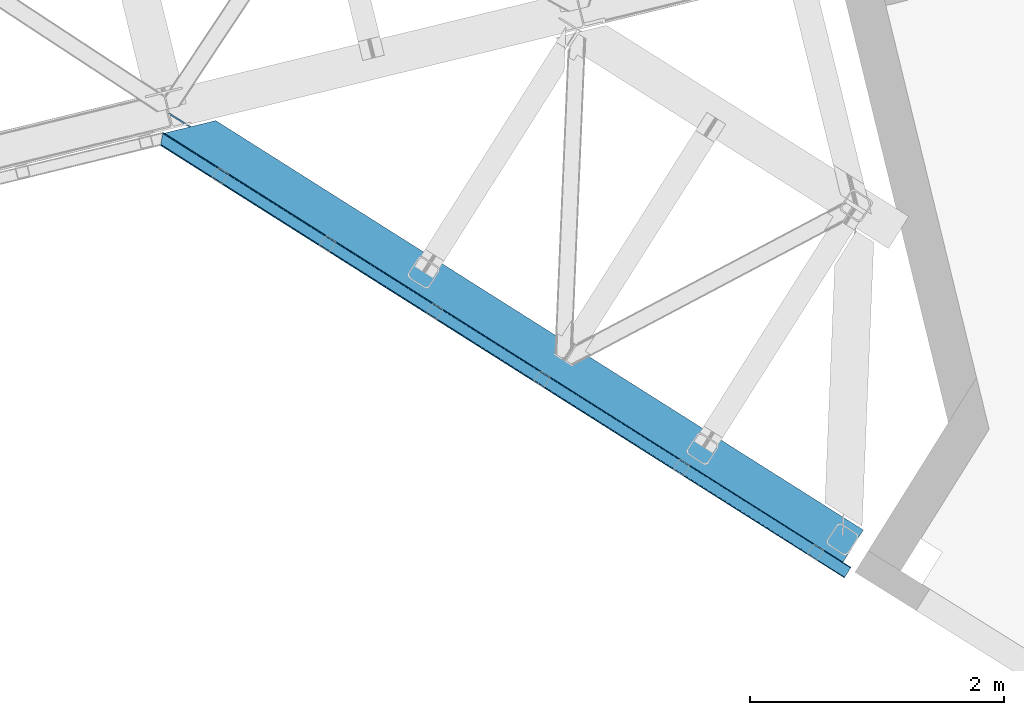
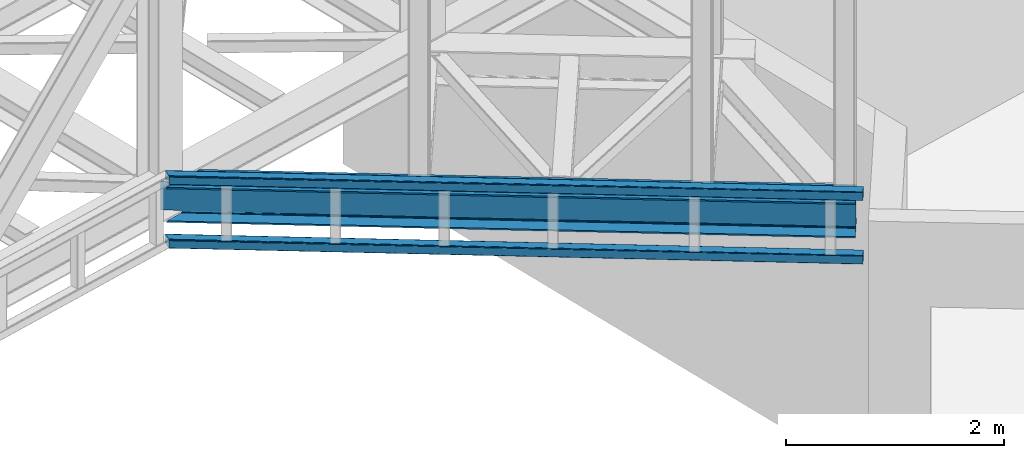
# One storey, part 72 of 92: 3 beams.
"""IFC4 building model written with IfcOpenShell, lengths in millimetres."""

from ifc_helpers import new_model, entity, si_unit, converted_unit, derived_unit, direction, frame, origin, place, context, subcontext, project, spatial, triangles, polygons, material, type_object, element, save


model = new_model("IFC4")

# Units and contexts
model_context = context("Model", 3, precision=0.01, world=origin(), true_north=direction((6.12303176911189e-17, 1.0)))
plan_context = context("Plan", 3, precision=0.01, world=origin(), true_north=direction((6.12303176911189e-17, 1.0)))
body_context = subcontext(model_context, "Body", "Model", "MODEL_VIEW")
ifc_project = project(units=[si_unit("LENGTHUNIT", "METRE", prefix="MILLI"), si_unit("AREAUNIT", "SQUARE_METRE"), si_unit("VOLUMEUNIT", "CUBIC_METRE"), converted_unit("PLANEANGLEUNIT", "DEGREE", entity("IfcRatioMeasure", 0.0174532925199433), si_unit("PLANEANGLEUNIT", "RADIAN"), dimensions=[0, 0, 0, 0, 0, 0, 0]), si_unit("MASSUNIT", "GRAM", prefix="KILO"), derived_unit("MASSDENSITYUNIT", [(si_unit("MASSUNIT", "GRAM", prefix="KILO"), 1), (si_unit("LENGTHUNIT", "METRE"), -3)]), derived_unit("MOMENTOFINERTIAUNIT", [(si_unit("LENGTHUNIT", "METRE"), 4)]), si_unit("TIMEUNIT", "SECOND"), si_unit("FREQUENCYUNIT", "HERTZ"), si_unit("THERMODYNAMICTEMPERATUREUNIT", "DEGREE_CELSIUS"), derived_unit("THERMALTRANSMITTANCEUNIT", [(si_unit("MASSUNIT", "GRAM", prefix="KILO"), 1), (si_unit("THERMODYNAMICTEMPERATUREUNIT", "KELVIN"), -1), (si_unit("TIMEUNIT", "SECOND"), -3)]), derived_unit("VOLUMETRICFLOWRATEUNIT", [(si_unit("LENGTHUNIT", "METRE"), 3), (si_unit("TIMEUNIT", "SECOND"), -1)]), derived_unit("MASSFLOWRATEUNIT", [(si_unit("MASSUNIT", "GRAM", prefix="KILO"), 1), (si_unit("TIMEUNIT", "SECOND"), -1)]), derived_unit("ROTATIONALFREQUENCYUNIT", [(si_unit("TIMEUNIT", "SECOND"), -1)]), si_unit("ELECTRICCURRENTUNIT", "AMPERE"), si_unit("ELECTRICVOLTAGEUNIT", "VOLT"), si_unit("POWERUNIT", "WATT"), si_unit("FORCEUNIT", "NEWTON", prefix="KILO"), si_unit("ILLUMINANCEUNIT", "LUX"), si_unit("LUMINOUSFLUXUNIT", "LUMEN"), si_unit("LUMINOUSINTENSITYUNIT", "CANDELA"), derived_unit("USERDEFINED", [(si_unit("MASSUNIT", "GRAM", prefix="KILO"), -1), (si_unit("LENGTHUNIT", "METRE"), -2), (si_unit("TIMEUNIT", "SECOND"), 3), (si_unit("LUMINOUSFLUXUNIT", "LUMEN"), 1)]), derived_unit("LINEARVELOCITYUNIT", [(si_unit("LENGTHUNIT", "METRE"), 1), (si_unit("TIMEUNIT", "SECOND"), -1)]), si_unit("PRESSUREUNIT", "PASCAL"), derived_unit("USERDEFINED", [(si_unit("LENGTHUNIT", "METRE"), -2), (si_unit("MASSUNIT", "GRAM", prefix="KILO"), 1), (si_unit("TIMEUNIT", "SECOND"), -2)]), derived_unit("LINEARFORCEUNIT", [(si_unit("MASSUNIT", "GRAM", prefix="KILO"), 1), (si_unit("LENGTHUNIT", "METRE"), 1), (si_unit("TIMEUNIT", "SECOND"), -2), (si_unit("LENGTHUNIT", "METRE"), -1)]), derived_unit("PLANARFORCEUNIT", [(si_unit("MASSUNIT", "GRAM", prefix="KILO"), 1), (si_unit("LENGTHUNIT", "METRE"), 1), (si_unit("TIMEUNIT", "SECOND"), -2), (si_unit("LENGTHUNIT", "METRE"), -2)])], contexts=[model_context, plan_context])

# Site, building, storey
site_placement = place(None, origin())
site = spatial("IfcSite", under=ifc_project, at=site_placement, CompositionType="ELEMENT")
building_placement = place(site_placement, origin())
building = spatial("IfcBuilding", under=site, at=building_placement, CompositionType="ELEMENT")
storey_placement = place(building_placement, frame((0.0, 0.0, 15900.0)))
storey = spatial("IfcBuildingStorey", under=building, at=storey_placement, Name="05", CompositionType="ELEMENT", Elevation=15900.0)

# Beams
ifc_material = material(Name="Metal painted (White)")
beam_type_1 = type_object("IfcBeamType", PredefinedType="BEAM")
beam_1_placement = place(storey_placement, frame((-5441.52, 12718.9, 3293.0)))
element("IfcBeam", 1, at=beam_1_placement, inside=storey, type_object=beam_type_1, material=ifc_material, ObjectType="Steel Beam", PredefinedType="BEAM", context=body_context, shape_type="Tessellation", body=[
    polygons([(5348.49662777212, 2.16573425859679e-12, 376.000000000005), (4.33146851719357e-12, 3381.27208353849, 376.000000000005), (165.112842431303, 3421.52008574059, 376.000000000005), (1093.62086845177, 2834.52555508644, 376.000000000005), (2173.67127244742, 2151.72727848622, 376.000000000005), (3253.72167644305, 1468.92900188599, 376.000000000005), (4333.77208043868, 786.130725285767, 376.000000000005), (5413.82248443432, 103.332448685544, 376.000000000005), (5348.49662777212, 2.16573425859679e-12, 392.000000000006), (4.33146851719357e-12, 3381.27208353849, 392.000000000006), (5508.8054784769, 253.576561191515, 392.000000000006), (405.184889401983, 3480.04018710194, 392.000000000006), (210.481526452577, 3432.57918246201, 356.00000000001), (194.703362949402, 3428.73308817842, 356.00000000001), (192.564591019407, 3428.21173989272, 362.419035512034), (186.123501179538, 3426.64165609887, 369.556349186108), (176.483729007347, 3424.29185964512, 374.325349715257), (405.18488940198, 3480.04018710194, 376.000000000001), (240.072046970671, 3439.79218489983, 376.000000000005), (228.701160394625, 3437.02041099531, 374.325349715252), (219.061388222436, 3434.67061454156, 369.556349186108), (212.620298382568, 3433.1005307477, 362.419035512034), (5348.49662777213, 2.16573425859679e-12, 2.16573425859679e-12), (5508.8054784769, 253.576561191515, 2.16573425859679e-12), (5508.8054784769, 253.576561191517, 16.000000000005), (5443.4796218147, 150.244112505971, 16.000000000005), (5438.98080212478, 143.127878927001, 17.674650284756), (5435.16688695074, 137.095027401615, 22.4436508139004), (5432.61851030462, 133.064004886613, 29.5809644879719), (5431.72363942969, 131.648498018593, 38.0000000000065), (5431.72363942968, 131.648498018593, 354.000000000006), (5432.61851030462, 133.064004886613, 362.419035512034), (5435.16688695074, 137.095027401613, 369.556349186108), (5438.98080212478, 143.127878927001, 374.325349715248), (5443.4796218147, 150.244112505971, 376.000000000005), (5508.8054784769, 253.576561191517, 376.000000000001), (5418.32130412425, 110.448682264514, 374.325349715252), (5422.13521929827, 116.481533789893, 369.556349186108), (5424.6835959444, 120.512556304902, 362.419035512034), (5425.57846681934, 121.928063172921, 354.000000000006), (5425.57846681934, 121.928063172921, 38.0000000000065), (5424.6835959444, 120.512556304902, 29.5809644879719), (5422.13521929827, 116.481533789891, 22.4436508138982), (5418.32130412425, 110.448682264514, 17.6746502847538), (5413.82248443432, 103.332448685544, 16.000000000005), (5348.49662777213, 2.16573425859679e-12, 16.000000000005), (4539.61123918262, 721.661679363439, 376.000000000005), (3635.74285655055, 1293.0792462209, 376.000000000005), (2731.87447391849, 1864.49681307837, 376.000000000005), (1828.00609128642, 2435.91437993584, 376.000000000005), (924.137708654353, 3007.3319467933, 376.000000000005), (4344.63319194877, 803.310832905123, 362.419035512034), (4345.5280628237, 804.726339773147, 354.000000000006), (3264.58278795313, 1486.10910950535, 362.419035512034), (3265.47765882807, 1487.52461637337, 354.000000000006), (2184.5323839575, 2168.90738610558, 362.419035512034), (2185.42725483244, 2170.3228929736, 354.000000000006), (1104.48197996186, 2851.7056627058, 362.419035512034), (1105.3768508368, 2853.12116957382, 354.000000000006), (4342.08481530264, 799.279810390127, 369.556349186108), (3262.034411307, 1482.07808699035, 369.556349186108), (2181.98400731137, 2164.87636359058, 369.556349186108), (1101.93360331573, 2847.6746401908, 369.556349186108), (4338.27090012861, 793.246958864737, 374.325349715252), (3258.22049613296, 1476.04523546496, 374.325349715252), (2178.17009213734, 2158.84351206519, 374.325349715252), (1098.1196881417, 2841.64178866541, 374.325349715257), (25.277767615974, 3535.84244536922, 356.000000000006), (25.3283289836519, 3535.91175797538, 353.999999604171), (4535.11241949271, 714.545445784473, 374.325349715252), (3631.24403686065, 1285.96301264194, 374.325349715252), (2727.37565422857, 1857.3805794994, 374.325349715252), (1823.5072715965, 2428.79814635686, 374.325349715252), (919.638888964427, 3000.21571321434, 374.325349715252), (4531.29850431868, 708.512594259083, 369.556349186108), (3627.43012168661, 1279.93016111655, 369.556349186108), (2723.56173905454, 1851.34772797402, 369.556349186108), (1819.69335642247, 2422.76529483148, 369.556349186108), (915.824973790396, 2994.18286168895, 369.556349186108), (4528.75012767254, 704.481571744081, 362.419035512034), (3624.88174504048, 1275.89913860154, 362.419035512034), (2721.01336240841, 1847.31670545901, 362.419035512034), (1817.14497977633, 2418.73427231648, 362.419035512034), (913.276597144271, 2990.15183917395, 362.419035512034), (4527.85525679761, 703.066064876057, 354.000000000006), (3623.98687416554, 1274.48363173353, 354.000000000006), (2720.11849153348, 1845.90119859099, 354.000000000006), (1816.2501089014, 2417.31876544846, 354.000000000006), (912.381726269338, 2988.73633230592, 354.000000000006), (40.8590053356167, 3539.70363258882, 353.999999900937), (40.9815723062875, 3539.73554863413, 356.000000000006), (25.3276901044207, 3535.9143676771, 35.9999997385335), (25.3273911802177, 3535.91558872633, 37.9999998013979), (40.8572852816821, 3539.71065868616, 38.0000002626798), (40.9802875962089, 3539.74079643359, 36.0000002701953), (1105.37685083679, 2853.12116957382, 38.0000000000044), (2185.42725483242, 2170.3228929736, 38.0000000000022), (3265.47765882807, 1487.52461637337, 38.0000000000065), (4345.5280628237, 804.726339773145, 38.0000000000065), (4527.85525679762, 703.066064876057, 38.0000000000065), (3623.98687416554, 1274.48363173353, 38.0000000000065), (2720.11849153347, 1845.90119859099, 38.0000000000065), (1816.2501089014, 2417.31876544846, 38.0000000000065), (912.381726269339, 2988.73633230592, 38.0000000000044), (4338.27090012861, 793.246958864737, 17.6746502847538), (4333.77208043868, 786.130725285771, 16.0000000000072), (3258.22049613296, 1476.04523546496, 17.6746502847538), (3253.72167644305, 1468.92900188599, 16.000000000005), (2178.17009213734, 2158.84351206518, 17.6746502847538), (2173.67127244742, 2151.72727848622, 16.000000000005), (1098.1196881417, 2841.64178866541, 17.674650284756), (1093.62086845177, 2834.52555508644, 16.000000000005), (4342.08481530264, 799.279810390123, 22.4436508139004), (3262.034411307, 1482.07808699035, 22.4436508138982), (2181.98400731137, 2164.87636359057, 22.4436508138982), (1101.93360331573, 2847.67464019079, 22.443650813896), (4344.63319194876, 803.310832905125, 29.5809644879698), (3264.58278795312, 1486.10910950534, 29.5809644879762), (2184.5323839575, 2168.90738610557, 29.5809644879741), (1104.48197996185, 2851.70566270579, 29.5809644879741), (192.564591019411, 3428.21173989272, 29.5809644879719), (186.123501179543, 3426.64165609887, 22.4436508139004), (176.483729007351, 3424.29185964512, 17.6746502847517), (165.112842431302, 3421.52008574059, 16.000000000005), (194.703362949402, 3428.73308817842, 36.0000000000026), (4.33146851719357e-12, 3381.27208353849, 16.000000000005), (3.24860138789518e-12, 3381.27208353849, 2.16573425859679e-12), (240.072046970672, 3439.79218489983, 16.000000000005), (405.18488940198, 3480.04018710194, 16.000000000005), (405.184889401981, 3480.04018710194, 2.16573425859679e-12), (210.481526452582, 3432.57918246201, 36.0000000000048), (212.620298382577, 3433.10053074771, 29.5809644879719), (219.061388222445, 3434.67061454156, 22.4436508139004), (228.701160394625, 3437.02041099531, 17.6746502847538), (924.137708654352, 3007.3319467933, 16.0000000000029), (1828.00609128641, 2435.91437993584, 16.0000000000029), (2731.87447391849, 1864.49681307837, 16.0000000000029), (3635.74285655055, 1293.0792462209, 16.000000000005), (4539.61123918262, 721.661679363439, 16.000000000005), (4528.75012767254, 704.481571744079, 29.5809644879719), (3624.88174504048, 1275.89913860154, 29.5809644879698), (2721.01336240841, 1847.31670545902, 29.5809644879719), (1817.14497977633, 2418.73427231648, 29.5809644879719), (913.276597144274, 2990.15183917395, 29.5809644879719), (4531.29850431868, 708.512594259083, 22.4436508138982), (3627.43012168661, 1279.93016111655, 22.4436508139025), (2723.56173905453, 1851.34772797401, 22.4436508139025), (1819.69335642247, 2422.76529483147, 22.4436508138982), (915.824973790396, 2994.18286168895, 22.4436508139004), (4535.11241949271, 714.545445784471, 17.674650284756), (3631.24403686065, 1285.96301264194, 17.6746502847517), (2727.37565422857, 1857.3805794994, 17.6746502847538), (1823.5072715965, 2428.79814635687, 17.674650284756), (919.638888964427, 3000.21571321434, 17.6746502847538)], [[[1, 2, 3, 4, 5, 6, 7, 8]], [[9, 10, 2, 1]], [[11, 12, 10, 9]], [[13, 14, 15, 16, 17, 3, 2, 10, 12, 18, 19, 20, 21, 22]], [[23, 24, 25, 26, 27, 28, 29, 30, 31, 32, 33, 34, 35, 36, 11, 9, 1, 8, 37, 38, 39, 40, 41, 42, 43, 44, 45, 46]], [[36, 18, 12, 11]], [[35, 47, 48, 49, 50, 51, 19, 18, 36]], [[52, 53, 40, 39]], [[54, 55, 53, 52]], [[56, 57, 55, 54]], [[58, 59, 57, 56]], [[60, 52, 39, 38]], [[61, 54, 52, 60]], [[62, 56, 54, 61]], [[63, 58, 56, 62]], [[64, 60, 38, 37]], [[65, 61, 60, 64]], [[66, 62, 61, 65]], [[67, 63, 62, 66]], [[7, 64, 37, 8]], [[6, 65, 64, 7]], [[5, 66, 65, 6]], [[4, 67, 66, 5]], [[3, 17, 67, 4]], [[17, 16, 63, 67]], [[16, 15, 58, 63]], [[59, 14, 68, 69]], [[58, 14, 59]], [[14, 58, 15]], [[70, 47, 35, 34]], [[71, 48, 47, 70]], [[72, 49, 48, 71]], [[73, 50, 49, 72]], [[74, 51, 50, 73]], [[75, 70, 34, 33]], [[76, 71, 70, 75]], [[77, 72, 71, 76]], [[78, 73, 72, 77]], [[79, 74, 73, 78]], [[80, 75, 33, 32]], [[81, 76, 75, 80]], [[82, 77, 76, 81]], [[83, 78, 77, 82]], [[84, 79, 78, 83]], [[85, 80, 32, 31]], [[86, 81, 80, 85]], [[87, 82, 81, 86]], [[88, 83, 82, 87]], [[89, 84, 83, 88]], [[22, 21, 79, 84]], [[21, 20, 74, 79]], [[20, 19, 51, 74]], [[13, 90, 91]], [[84, 13, 22]], [[89, 13, 84]], [[13, 89, 90]], [[91, 68, 14, 13]], [[92, 93, 69, 68, 91, 90, 94, 95]], [[69, 93, 96, 97, 98, 99, 41, 40, 53, 55, 57, 59]], [[30, 100, 101, 102, 103, 104, 94, 90, 89, 88, 87, 86, 85, 31]], [[105, 106, 45, 44]], [[107, 108, 106, 105]], [[109, 110, 108, 107]], [[111, 112, 110, 109]], [[113, 105, 44, 43]], [[114, 107, 105, 113]], [[115, 109, 107, 114]], [[116, 111, 109, 115]], [[117, 113, 43, 42]], [[118, 114, 113, 117]], [[119, 115, 114, 118]], [[120, 116, 115, 119]], [[99, 117, 42, 41]], [[98, 118, 117, 99]], [[97, 119, 118, 98]], [[96, 120, 119, 97]], [[121, 122, 116, 120]], [[122, 123, 111, 116]], [[123, 124, 112, 111]], [[125, 93, 92]], [[120, 125, 121]], [[96, 125, 120]], [[125, 96, 93]], [[46, 126, 127, 23]], [[45, 106, 108, 110, 112, 124, 126, 46]], [[128, 129, 130, 127, 126, 124, 123, 122, 121, 125, 131, 132, 133, 134]], [[23, 127, 130, 24]], [[24, 130, 129, 25]], [[25, 129, 128, 135, 136, 137, 138, 139, 26]], [[140, 100, 30, 29]], [[141, 101, 100, 140]], [[142, 102, 101, 141]], [[143, 103, 102, 142]], [[144, 104, 103, 143]], [[145, 140, 29, 28]], [[146, 141, 140, 145]], [[147, 142, 141, 146]], [[148, 143, 142, 147]], [[149, 144, 143, 148]], [[150, 145, 28, 27]], [[151, 146, 145, 150]], [[152, 147, 146, 151]], [[153, 148, 147, 152]], [[154, 149, 148, 153]], [[139, 150, 27, 26]], [[138, 151, 150, 139]], [[137, 152, 151, 138]], [[136, 153, 152, 137]], [[135, 154, 153, 136]], [[128, 134, 154, 135]], [[134, 133, 149, 154]], [[133, 132, 144, 149]], [[104, 131, 95, 94]], [[104, 132, 131]], [[132, 104, 144]], [[131, 125, 92, 95]]], closed=True),
])
beam_type_2 = type_object("IfcBeamType", PredefinedType="BEAM")
beam_2_placement = place(storey_placement, frame((-5471.54, 12594.31, 3780.01)))
element("IfcBeam", 2, at=beam_2_placement, inside=storey, type_object=beam_type_2, ObjectType="Steel Beam", PredefinedType="BEAM", context=body_context, shape_type="Tessellation", body=[
    triangles([(15.8013610839844, 3503.0245513916, 99.9985473632805), (1.75745086669849, 3417.25885620117, 99.9985473632805), (5436.55335826278, 76.0732635498061, 99.9985473632805), (5393.80616054535, 8.45297241210938, 99.9985473632805), (1.13539581298755, 3413.46722717285, 98.5335205078118), (5391.76071853638, 5.21828613281286, 99.2381286621094), (0.517410278320313, 3409.67792358399, 97.070819091794), (5390.02611329555, 2.47543029785265, 97.070819091794), (0.258705139160156, 3408.1070892334, 93.533825683593), (5388.86898915768, 0.644146728516716, 93.8268310546846), (0.0, 3406.53741760254, 89.999157714843), (5388.46101987362, 0.0, 89.999157714843), (5388.46101987362, 0.0, 9.9993896484375), (0.0, 3406.53741760254, 9.9993896484375), (5388.86898915768, 0.644146728516716, 6.17171630859229), (5390.02611329555, 2.47543029785265, 2.92772827148292), (0.258705139160156, 3408.1070892334, 6.46239624023292), (5391.76071853638, 5.21828613281286, 0.760418701171147), (0.517410278320313, 3409.67792358399, 2.92772827148292), (5393.80616054535, 8.45297241210938, 0.0), (1.13539581298755, 3413.46722717285, 1.46270141601417), (1.75745086669849, 3417.25769348145, 0.0), (15.8013610839844, 3503.0245513916, 0.0), (5436.55335826278, 76.0732635498061, 0.0), (5438.59880481362, 79.3079498291027, 0.760418701171147), (5440.33340778351, 82.0508056640629, 2.92772827148292), (16.4234161376953, 3506.8150177002, 1.46270141601417), (5441.49046606421, 83.8820892333988, 6.17171630859229), (17.046052551269, 3510.60548400879, 2.92772827148292), (5441.89843534827, 84.5262359619155, 9.9993896484375), (17.3001068115227, 3512.17515563965, 6.46239624023292), (17.5588119506829, 3513.74482727051, 9.9993896484375), (5441.89843534827, 84.5262359619155, 89.999157714843), (17.5588119506829, 3513.74482727051, 89.999157714843), (17.3001068115227, 3512.17515563965, 93.533825683593), (5441.49046606421, 83.8820892333988, 93.8268310546846), (17.0454711914063, 3510.60548400879, 97.070819091794), (5440.33340778351, 82.0508056640629, 97.070819091794), (16.4234161376953, 3506.8150177002, 98.5335205078118), (5438.59880481362, 79.3079498291027, 99.2381286621094), (5437.66312882304, 77.8243194580082, 92.0687988281243), (5438.82018710375, 79.6567657470714, 88.8248107910149), (5439.22815638781, 80.2997497558608, 84.9994628906243), (5433.88307930231, 71.8467773437515, 94.9988525390618), (5435.92852585316, 75.081463623048, 94.2384338378906), (5437.66312882304, 77.8243194580082, 7.92742309570167), (5439.22815638781, 80.2997497558608, 14.9990844726563), (5438.82018710375, 79.6567657470714, 11.171411132811), (5433.88307930231, 71.8467773437515, 4.99969482421875), (5435.92852585316, 75.081463623048, 5.7601135253899), (5392.69638998508, 6.70191650390734, 92.0687988281243), (5396.47644177675, 12.6794586181641, 94.9988525390618), (5394.43099522591, 9.44477233886755, 94.2384338378906), (5391.13129656315, 4.22648620605469, 84.9994628906243), (5391.53926584721, 4.86947021484411, 88.8248107910149), (5392.69638998508, 6.70191650390734, 7.92742309570167), (5396.47644177675, 12.6794586181641, 4.99969482421875), (5394.43099522591, 9.44477233886755, 5.7601135253899), (5391.13129656315, 4.22648620605469, 14.9990844726563), (5391.53926584721, 4.86947021484411, 11.171411132811), (16.4234161376953, 3506.8150177002, 11.4644165039063), (16.6821212768555, 3508.38468933106, 14.9990844726563), (16.1647109985352, 3505.24418334961, 7.92742309570167), (16.6821212768555, 3508.38468933106, 84.9994628906243), (14.9252517700188, 3497.66441345215, 4.99969482421875), (2.63356018066406, 3422.6178314209, 4.99969482421875), (15.5473068237297, 3501.45487976074, 6.46239624023292), (16.1647109985352, 3505.24418334961, 92.0687988281243), (16.4234161376953, 3506.8150177002, 88.5341308593743), (14.9252517700188, 3497.66441345215, 94.9988525390618), (15.5473068237297, 3501.45487976074, 93.533825683593), (1.39410095214771, 3415.03806152344, 7.92742309570167), (2.01615600585865, 3418.82852783203, 6.46239624023292), (0.880760192871094, 3411.89871826172, 14.9990844726563), (1.13539581298755, 3413.46722717285, 11.4644165039063), (2.01615600585865, 3418.82852783203, 93.533825683593), (1.39410095214771, 3415.03806152344, 92.0687988281243), (1.13539581298755, 3413.46722717285, 88.5341308593743), (2.63356018066406, 3422.6178314209, 94.9988525390618), (0.880760192871094, 3411.89871826172, 84.9994628906243)], [[1, 2, 3], [4, 3, 2], [4, 2, 5], [6, 5, 7], [8, 7, 9], [10, 9, 11], [11, 12, 10], [9, 10, 8], [7, 8, 6], [5, 6, 4], [13, 12, 14], [11, 14, 12], [15, 13, 14], [16, 15, 17], [18, 16, 19], [20, 18, 21], [21, 22, 20], [19, 21, 18], [17, 19, 16], [14, 17, 15], [22, 23, 24], [24, 20, 22], [25, 24, 23], [26, 25, 27], [28, 26, 29], [30, 28, 31], [31, 32, 30], [29, 31, 28], [27, 29, 26], [23, 27, 25], [33, 30, 32], [32, 34, 33], [33, 34, 35], [36, 35, 37], [38, 37, 39], [40, 39, 1], [1, 3, 40], [39, 40, 38], [37, 38, 36], [35, 36, 33], [36, 41, 42], [43, 30, 33], [36, 42, 33], [36, 38, 41], [42, 43, 33], [41, 38, 40], [44, 3, 4], [3, 45, 40], [45, 3, 44], [45, 41, 40], [28, 46, 26], [47, 30, 43], [30, 48, 28], [48, 30, 47], [28, 48, 46], [24, 49, 20], [25, 26, 46], [46, 50, 25], [50, 49, 24], [24, 25, 50], [51, 6, 8], [4, 52, 44], [4, 53, 52], [53, 4, 6], [51, 53, 6], [54, 12, 13], [10, 55, 51], [8, 10, 51], [55, 10, 12], [54, 55, 12], [18, 56, 16], [20, 49, 57], [57, 58, 20], [58, 56, 18], [18, 20, 58], [15, 16, 56], [13, 59, 54], [60, 13, 15], [13, 60, 59], [60, 15, 56], [61, 62, 32], [63, 31, 29], [63, 29, 27], [32, 62, 64], [32, 31, 61], [63, 61, 31], [65, 23, 66], [27, 23, 67], [65, 67, 23], [27, 67, 63], [35, 68, 37], [64, 34, 32], [34, 69, 35], [69, 34, 64], [35, 69, 68], [1, 70, 2], [39, 37, 68], [71, 39, 68], [1, 71, 70], [1, 39, 71], [72, 21, 19], [22, 66, 23], [22, 73, 66], [73, 22, 21], [72, 73, 21], [74, 14, 11], [17, 75, 72], [72, 19, 17], [17, 14, 75], [74, 75, 14], [5, 2, 76], [77, 5, 76], [78, 9, 77], [79, 2, 70], [2, 79, 76], [77, 7, 5], [11, 80, 74], [9, 78, 11], [80, 11, 78], [9, 7, 77], [79, 70, 44], [44, 52, 79], [55, 54, 80], [51, 55, 78], [53, 51, 77], [52, 53, 76], [76, 79, 52], [77, 76, 53], [78, 77, 51], [80, 78, 55], [54, 59, 74], [74, 80, 54], [57, 66, 73], [58, 73, 72], [56, 72, 75], [60, 75, 74], [74, 59, 60], [75, 60, 56], [72, 56, 58], [73, 58, 57], [65, 66, 49], [57, 49, 66], [47, 62, 61], [48, 61, 63], [46, 63, 67], [50, 67, 65], [65, 49, 50], [67, 50, 46], [63, 46, 48], [61, 48, 47], [47, 43, 62], [64, 62, 43], [45, 44, 70], [41, 45, 71], [42, 41, 68], [43, 42, 69], [69, 64, 43], [68, 69, 42], [71, 68, 41], [70, 71, 45]]),
])
beam_type_3 = type_object("IfcBeamType", PredefinedType="BEAM")
beam_3_placement = place(storey_placement, frame((-5471.54, 12594.31, 3068.01)))
element("IfcBeam", 3, at=beam_3_placement, inside=storey, type_object=beam_type_3, ObjectType="Steel Beam", PredefinedType="BEAM", context=body_context, shape_type="Tessellation", body=[
    triangles([(5441.89843534827, 84.5262359619155, 89.999157714843), (17.5588119506829, 3513.74482727051, 49.9934600830093), (17.5588119506829, 3513.74482727051, 89.999157714843), (5441.89843534827, 84.5262359619155, 9.9993896484375), (17.5588119506829, 3513.74482727051, 37.9174530029304), (17.5588119506829, 3513.74482727051, 9.952880859375), (5438.56435924172, 79.2521392822273, 0.733676147461665), (5436.55335826278, 76.0732635498061, 0.0), (15.8013610839844, 3503.0245513916, 0.0), (5440.31632125378, 82.0217376708988, 2.89517211914063), (16.4106262207024, 3506.74990539551, 1.42898254394458), (5441.48746161461, 83.8751129150405, 6.15078735351563), (17.0402389526362, 3510.56943969727, 2.89517211914063), (17.3018508911127, 3512.16701660156, 6.44611816406177), (1.75745086669849, 3417.25769348145, 0.0), (5393.80616054535, 8.45297241210938, 0.0), (5389.43155474663, 1.53711547851708, 4.24974060058594), (5388.65123355389, 0.299981689453489, 7.36117858886792), (0.0895294189449487, 3407.09203491211, 7.39373474121021), (0.136038208007449, 3407.35364685059, 6.17287902831958), (5390.73057610989, 3.59164123535265, 1.81849365234302), (0.349978637695131, 3408.65589294434, 4.35438537597656), (0.517410278320313, 3409.67792358399, 2.92889099121021), (5392.39668989182, 6.22287597656396, 0.353466796874272), (0.761000061034792, 3411.19178466797, 1.95104370117406), (1.03133239746057, 3412.83354492188, 0.890643310547603), (1.30050201415997, 3414.47763061524, 0.55926818847729), (5388.46101987362, 0.0, 9.9993896484375), (0.0, 3406.53741760254, 9.9993896484375), (5388.46101987362, 0.0, 89.999157714843), (0.0, 3406.53741760254, 49.9934600830093), (0.0, 3406.53741760254, 89.999157714843), (5393.80616054535, 8.45297241210938, 99.9997100830078), (1.75745086669849, 3417.25769348145, 99.9997100830078), (1.13539581298755, 3413.46722717285, 98.5346832275391), (5391.76071853638, 5.21828613281286, 99.2381286621094), (0.517410278320313, 3409.67792358399, 97.0708190917976), (5390.02611329555, 2.47543029785265, 97.0708190917976), (0.258705139160156, 3408.1070892334, 93.5349884033203), (5388.86898915768, 0.644146728516716, 93.8268310546882), (15.8013610839844, 3503.0245513916, 99.9997100830078), (5436.55335826278, 76.0732635498061, 99.9997100830078), (17.3001068115227, 3512.17515563965, 93.5349884033203), (5441.49046606421, 83.8820892333988, 93.8268310546882), (17.046052551269, 3510.60548400879, 97.0708190917976), (5440.33340778351, 82.0508056640629, 97.0708190917976), (16.4234161376953, 3506.8150177002, 98.5346832275391), (5438.59880481362, 79.3079498291027, 99.2381286621094), (16.6821212768555, 3508.38468933106, 14.9990844726563), (16.5879409790032, 3507.82890930176, 12.393429565429), (16.5460830688471, 3507.56846008301, 11.1725738525383), (14.9252517700188, 3497.66441345215, 4.99969482421875), (2.63356018066406, 3422.6178314209, 4.99969482421875), (2.01615600585865, 3418.82852783203, 6.46355895996021), (1.39410095214771, 3415.03806152344, 7.92858581542896), (15.5955596923823, 3501.76648864746, 5.76127624511719), (15.3833633422846, 3500.45726623535, 5.51826782226635), (16.1647109985352, 3505.24418334961, 7.92858581542896), (15.915307617187, 3503.71520690918, 6.97515563964771), (16.3321426391594, 3506.26621398926, 9.3552429199226), (16.6821212768555, 3508.38468933106, 84.9994628906243), (16.6821212768555, 3508.38468933106, 49.9934600830093), (1.39410095214771, 3415.03806152344, 92.0711242675789), (0.880760192871094, 3411.89871826172, 14.9990844726563), (1.13539581298755, 3413.46722717285, 11.4644165039063), (0.880760192871094, 3411.89871826172, 49.9934600830093), (1.13539581298755, 3413.46722717285, 88.5352935791016), (0.880760192871094, 3411.89871826172, 84.9994628906243), (16.1647109985352, 3505.24418334961, 92.0711242675789), (16.4234161376953, 3506.8150177002, 88.5352935791016), (14.9252517700188, 3497.66441345215, 95.0000152587891), (2.63356018066406, 3422.6178314209, 95.0000152587891), (15.5473068237297, 3501.45487976074, 93.5349884033203), (2.01615600585865, 3418.82852783203, 93.5349884033203), (5437.66312882304, 77.8243194580082, 92.0711242675789), (5438.82018710375, 79.6567657470714, 88.8259735107422), (5439.22815638781, 80.2997497558608, 84.9994628906243), (5439.22815638781, 80.2997497558608, 14.9990844726563), (5433.88307930231, 71.8467773437515, 95.0000152587891), (5435.92852585316, 75.081463623048, 94.2384338378906), (5436.95408098698, 76.7069458007827, 6.81818847656177), (5439.03794270754, 79.9997680664073, 12.3608734130867), (5438.2531000793, 78.7626342773438, 9.24943542480469), (5435.29254768491, 74.0768737792969, 5.35432434082031), (5433.88307930231, 71.8467773437515, 4.99969482421875), (5392.69638998508, 6.70191650390734, 92.0711242675789), (5391.53926584721, 4.86947021484411, 88.8259735107422), (5396.47644177675, 12.6794586181641, 95.0000152587891), (5394.43099522591, 9.44477233886755, 94.2384338378906), (5391.13129656315, 4.22648620605469, 84.9994628906243), (5391.13129656315, 4.22648620605469, 14.9990844726563), (5392.69638998508, 6.70191650390734, 7.92858581542896), (5396.47644177675, 12.6794586181641, 4.99969482421875), (5394.43099522591, 9.44477233886755, 5.76127624511719), (5391.53926584721, 4.86947021484411, 11.1725738525383)], [[1, 2, 3], [1, 4, 2], [4, 5, 2], [4, 6, 5], [7, 8, 9], [10, 7, 11], [12, 10, 13], [4, 12, 14], [14, 6, 4], [13, 14, 12], [11, 13, 10], [9, 11, 7], [15, 9, 8], [8, 16, 15], [17, 18, 19], [19, 20, 17], [21, 17, 22], [22, 23, 21], [24, 21, 25], [25, 26, 24], [16, 24, 27], [18, 28, 29], [29, 19, 18], [27, 15, 16], [26, 27, 24], [23, 25, 21], [20, 22, 17], [30, 31, 28], [31, 30, 32], [31, 29, 28], [33, 34, 35], [36, 35, 37], [38, 37, 39], [40, 39, 32], [32, 30, 40], [39, 40, 38], [37, 38, 36], [35, 36, 33], [41, 34, 42], [33, 42, 34], [1, 3, 43], [44, 43, 45], [46, 45, 47], [48, 47, 41], [41, 42, 48], [47, 48, 46], [45, 46, 44], [43, 44, 1], [49, 6, 50], [51, 50, 6], [52, 9, 53], [15, 53, 9], [54, 27, 55], [53, 15, 54], [54, 15, 27], [25, 23, 55], [55, 27, 26], [55, 26, 25], [56, 9, 57], [52, 57, 9], [58, 11, 59], [58, 13, 11], [11, 56, 59], [9, 56, 11], [6, 14, 51], [14, 13, 58], [58, 60, 14], [60, 51, 14], [2, 61, 3], [6, 49, 5], [5, 62, 2], [49, 62, 5], [62, 61, 2], [63, 39, 37], [64, 65, 29], [65, 55, 19], [64, 31, 66], [67, 39, 63], [32, 67, 68], [68, 66, 31], [67, 32, 39], [22, 55, 23], [19, 55, 20], [22, 20, 55], [31, 64, 29], [31, 32, 68], [19, 29, 65], [45, 43, 69], [43, 3, 70], [61, 70, 3], [70, 69, 43], [41, 71, 72], [69, 73, 47], [73, 71, 41], [69, 47, 45], [73, 41, 47], [34, 41, 72], [72, 74, 34], [74, 63, 35], [35, 34, 74], [63, 37, 35], [44, 75, 76], [4, 1, 77], [44, 76, 1], [44, 46, 75], [76, 77, 1], [78, 4, 77], [75, 46, 48], [79, 42, 33], [42, 80, 48], [80, 42, 79], [80, 75, 48], [10, 81, 7], [82, 4, 78], [83, 12, 4], [83, 4, 82], [12, 83, 10], [81, 8, 7], [10, 83, 81], [81, 84, 8], [8, 85, 16], [85, 8, 84], [86, 40, 87], [33, 88, 79], [33, 89, 88], [89, 33, 36], [86, 36, 38], [86, 89, 36], [90, 28, 91], [87, 30, 90], [38, 40, 86], [30, 87, 40], [90, 30, 28], [24, 92, 21], [16, 85, 93], [93, 94, 16], [94, 92, 24], [24, 16, 94], [17, 21, 92], [28, 95, 91], [92, 95, 18], [28, 18, 95], [92, 18, 17], [52, 53, 85], [93, 85, 53], [93, 53, 54], [94, 54, 55], [92, 55, 65], [95, 65, 64], [64, 91, 95], [65, 95, 92], [55, 92, 94], [54, 94, 93], [90, 66, 68], [90, 91, 66], [64, 66, 91], [87, 90, 68], [86, 87, 67], [89, 86, 63], [88, 89, 74], [74, 72, 88], [63, 74, 89], [67, 63, 86], [68, 67, 87], [72, 71, 79], [79, 88, 72], [80, 79, 71], [75, 80, 73], [76, 75, 69], [77, 76, 70], [70, 61, 77], [69, 70, 76], [73, 69, 75], [71, 73, 80], [77, 62, 78], [62, 77, 61], [62, 49, 78], [78, 49, 50], [82, 51, 60], [82, 50, 51], [83, 58, 59], [83, 60, 58], [81, 56, 57], [81, 59, 56], [84, 57, 52], [52, 85, 84], [57, 84, 81], [59, 81, 83], [60, 83, 82], [50, 82, 78]]),
])

save(model, "model.ifc")
